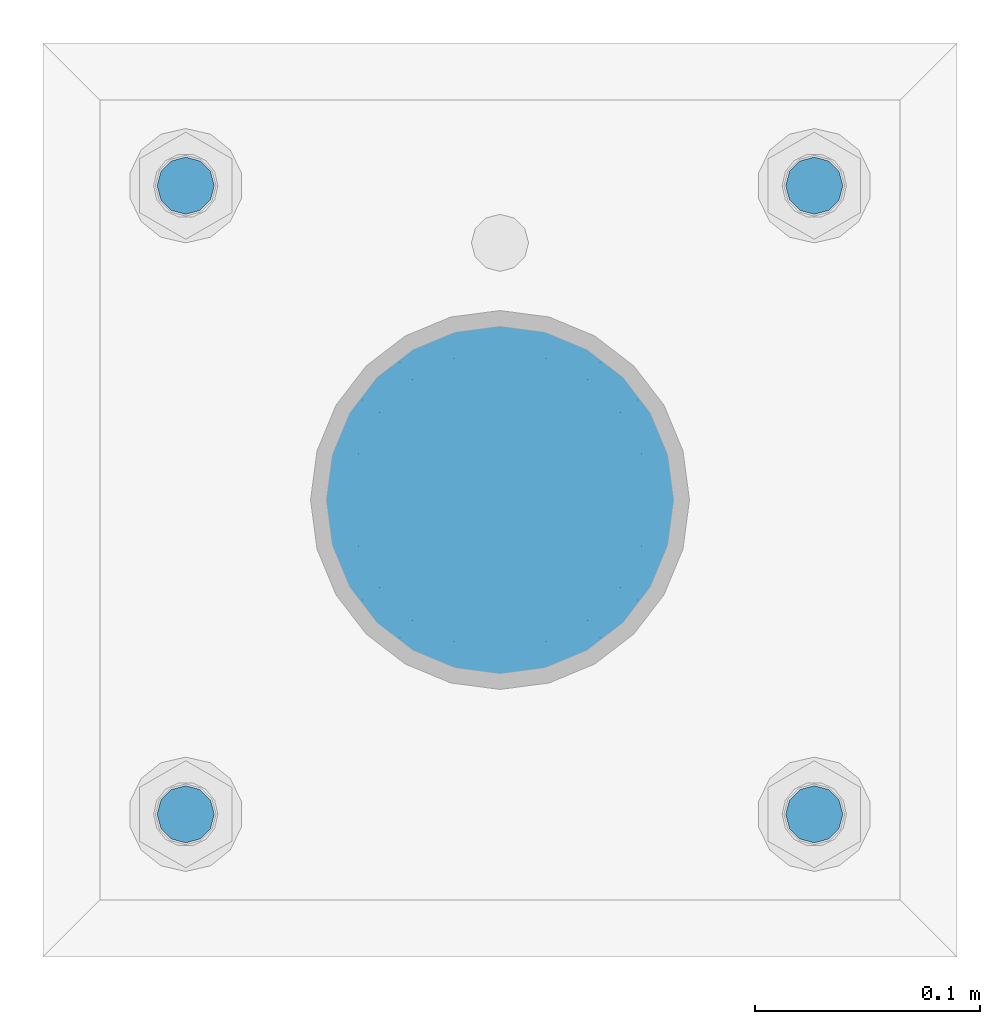
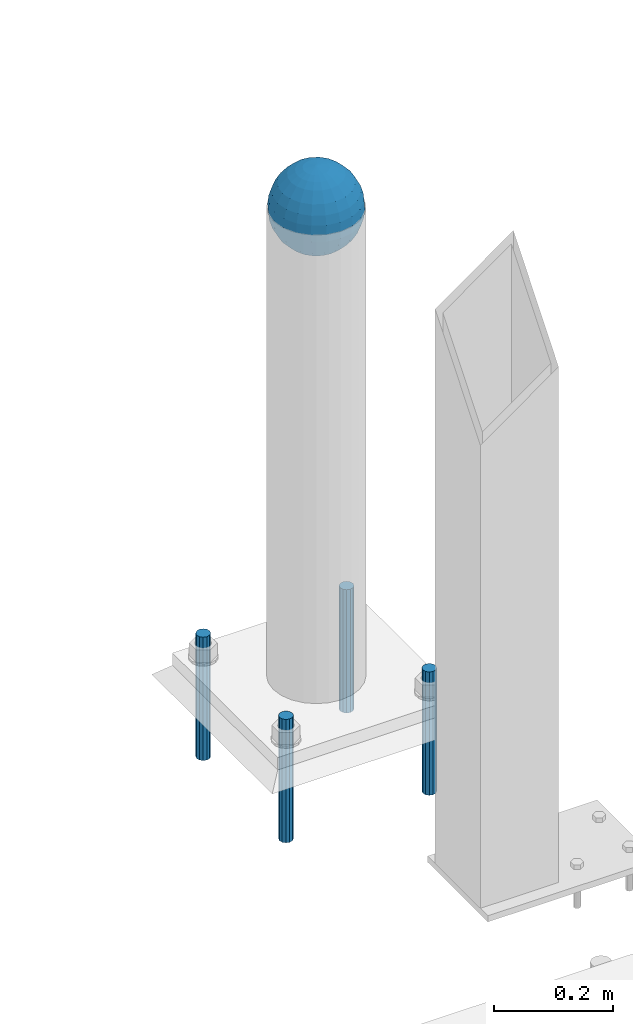
# One storey, part 1586 of 3843: 5 columns, 2 elements without a shape of their own.
"""IFC2X3 building model written with IfcOpenShell, lengths in millimetres."""

from ifc_helpers import new_model, si_unit, frame, origin_with_axes, place, context, subcontext, project, spatial, faceted_brep, material, type_object, element, aggregate, save


model = new_model("IFC2X3")

# Units and contexts
model_context = context("Model", 3, precision=1e-05, world=origin_with_axes())
body_context = subcontext(model_context, "Body", "Model", "MODEL_VIEW")
ifc_project = project(units=[si_unit("LENGTHUNIT", "METRE", prefix="MILLI"), si_unit("AREAUNIT", "SQUARE_METRE"), si_unit("VOLUMEUNIT", "CUBIC_METRE"), si_unit("MASSUNIT", "GRAM", prefix="KILO"), si_unit("TIMEUNIT", "SECOND"), si_unit("PLANEANGLEUNIT", "RADIAN"), si_unit("SOLIDANGLEUNIT", "STERADIAN"), si_unit("THERMODYNAMICTEMPERATUREUNIT", "DEGREE_CELSIUS"), si_unit("LUMINOUSINTENSITYUNIT", "LUMEN")], contexts=[model_context])

# Site, building, storey
site_placement = place(None, origin_with_axes())
site = spatial("IfcSite", under=ifc_project, at=site_placement, CompositionType="ELEMENT")
building_placement = place(site_placement, origin_with_axes())
building = spatial("IfcBuilding", under=site, at=building_placement, Name="Undefined", CompositionType="ELEMENT")
storey_placement = place(building_placement, origin_with_axes())
storey = spatial("IfcBuildingStorey", under=building, at=storey_placement, Name="Undefined", CompositionType="ELEMENT", Elevation=0.0)

# Assembly, column
assembly_1_placement = place(storey_placement, origin_with_axes())
assembly_1 = element("IfcElementAssembly", 1, at=assembly_1_placement, inside=storey, Name="CONC. FILL", AssemblyPlace="NOTDEFINED", PredefinedType="REINFORCEMENT_UNIT")
ifc_material_1 = material(Name="CONCRETE/1500")
column_type_1 = type_object("IfcColumnType", PredefinedType="NOTDEFINED")
column_1_placement = place(assembly_1_placement, frame((48488.6, 93129.1, 31411.8625), z_axis=(-1.0, 0.0, 0.0), x_axis=(0.0, 0.0, 1.0)))
column_1 = element("IfcColumn", 2, at=column_1_placement, type_object=column_type_1, material=ifc_material_1, Name="CONC. FILL", context=body_context, shape_type="Brep", body=[
    faceted_brep([(0.0, 0.0, 2.0), (0.0, -0.619999999995343, 1.89999999999964), (3.36549999999988, -7.1422259999963, 21.9814139999999), (3.36549999999988, 0.0, 23.1139999999996), (0.0, -1.17999999999302, 1.6200000000008), (3.36549999999988, -13.5910319999966, 18.6992260000006), (0.0, -1.61999999999534, 1.18000000000029), (3.36549999999988, -18.699225999997, 13.5910320000003), (0.0, -1.89999999999418, 0.6200000000008), (3.36549999999988, -21.9814139999944, 7.14222599999994), (0.0, -2.0, 0.0), (3.36549999999988, -23.1140000000014, 0.0), (0.0, -1.89999999999418, -0.6200000000008), (3.36549999999988, -21.9814139999944, -7.14222599999994), (0.0, -1.61999999999534, -1.18000000000029), (3.36549999999988, -18.699225999997, -13.5910320000003), (0.0, -1.17999999999302, -1.6200000000008), (3.36549999999988, -13.5910319999966, -18.6992260000006), (0.0, -0.619999999995343, -1.89999999999964), (3.36549999999988, -7.1422259999963, -21.9814139999999), (0.0, 0.0, -2.0), (3.36549999999988, 0.0, -23.1139999999996), (0.0, 0.619999999995343, -1.89999999999964), (3.36549999999988, 7.1422259999963, -21.9814139999999), (0.0, 1.17999999999302, -1.6200000000008), (3.36549999999988, 13.5910319999966, -18.6992260000006), (0.0, 1.61999999999534, -1.18000000000029), (3.36549999999988, 18.699225999997, -13.5910320000003), (0.0, 1.89999999999418, -0.6200000000008), (3.36549999999988, 21.9814139999944, -7.14222599999994), (0.0, 2.0, 0.0), (3.36549999999988, 23.1140000000014, 0.0), (0.0, 1.89999999999418, 0.6200000000008), (3.36549999999988, 21.9814139999944, 7.14222599999994), (0.0, 1.61999999999534, 1.18000000000029), (3.36549999999988, 18.699225999997, 13.5910320000003), (0.0, 1.17999999999302, 1.6200000000008), (3.36549999999988, 13.5910319999966, 18.6992260000006), (0.0, 0.619999999995343, 1.89999999999964), (3.36549999999988, 7.1422259999963, 21.9814139999999), (8.41374999999971, -11.1214661999984, 34.2282018000005), (8.41374999999971, 0.0, 35.9917999999998), (8.41374999999971, -21.1631784000056, 29.1173662000001), (8.41374999999971, -29.1173661999928, 21.1631784000001), (8.41374999999971, -34.2282017999969, 11.1214662000002), (8.41374999999971, -35.9918000000034, 0.0), (8.41374999999971, -34.2282017999969, -11.1214662000002), (8.41374999999971, -29.1173661999928, -21.1631784000001), (8.41374999999971, -21.1631784000056, -29.1173662000001), (8.41374999999971, -11.1214661999984, -34.2282018000005), (8.41374999999971, 0.0, -35.9917999999998), (8.41374999999971, 11.1214661999984, -34.2282018000005), (8.41374999999971, 21.1631784000056, -29.1173662000001), (8.41374999999971, 29.1173661999928, -21.1631784000001), (8.41374999999971, 34.2282017999969, -11.1214662000002), (8.41374999999971, 35.9918000000034, 0.0), (8.41374999999971, 34.2282017999969, 11.1214662000002), (8.41374999999971, 29.1173661999928, 21.1631784000001), (8.41374999999971, 21.1631784000056, 29.1173662000001), (8.41374999999971, 11.1214661999984, 34.2282018000005), (16.8274999999994, -15.3047700000025, 47.1030300000002), (16.8274999999994, 0.0, 49.5300000000007), (16.8274999999994, -29.1236400000053, 40.0697700000001), (16.8274999999994, -40.0697700000019, 29.1236399999998), (16.8274999999994, -47.1030299999984, 15.3047700000006), (16.8274999999994, -49.5299999999988, 0.0), (16.8274999999994, -47.1030299999984, -15.3047700000006), (16.8274999999994, -40.0697700000019, -29.1236399999998), (16.8274999999994, -29.1236400000053, -40.0697700000001), (16.8274999999994, -15.3047700000025, -47.1030300000002), (16.8274999999994, 0.0, -49.5300000000007), (16.8274999999994, 15.3047700000025, -47.1030300000002), (16.8274999999994, 29.1236400000053, -40.0697700000001), (16.8274999999994, 40.0697700000019, -29.1236399999998), (16.8274999999994, 47.1030299999984, -15.3047700000006), (16.8274999999994, 49.5299999999988, 0.0), (16.8274999999994, 47.1030299999984, 15.3047700000006), (16.8274999999994, 40.0697700000019, 29.1236399999998), (16.8274999999994, 29.1236400000053, 40.0697700000001), (16.8274999999994, 15.3047700000025, 47.1030300000002), (33.6549999999988, -20.4063599999936, 62.8040400000009), (33.6549999999988, 0.0, 66.0400000000009), (33.6549999999988, -38.831520000007, 53.4263599999995), (33.6549999999988, -53.4263599999977, 38.8315199999997), (33.6549999999988, -62.8040400000027, 20.4063600000009), (33.6549999999988, -66.0399999999936, 0.0), (33.6549999999988, -62.8040400000027, -20.4063600000009), (33.6549999999988, -53.4263599999977, -38.8315199999997), (33.6549999999988, -38.831520000007, -53.4263599999995), (33.6549999999988, -20.4063599999936, -62.8040400000009), (33.6549999999988, 0.0, -66.0400000000009), (33.6549999999988, 20.4063599999936, -62.8040400000009), (33.6549999999988, 38.831520000007, -53.4263599999995), (33.6549999999988, 53.4263599999977, -38.8315199999997), (33.6549999999988, 62.8040400000027, -20.4063600000009), (33.6549999999988, 66.0399999999936, 0.0), (33.6549999999988, 62.8040400000027, 20.4063600000009), (33.6549999999988, 53.4263599999977, 38.8315199999997), (33.6549999999988, 38.831520000007, 53.4263599999995), (33.6549999999988, 20.4063599999936, 62.8040400000009), (50.4824999999983, -23.3907901500061, 71.9891308499991), (50.4824999999983, 0.0, 75.6983500000006), (50.4824999999983, -44.5106298000028, 61.23996515), (50.4824999999983, -61.2399651500018, 44.5106297999992), (50.4824999999983, -71.9891308499937, 23.3907901500006), (50.4824999999983, -75.698350000006, 0.0), (50.4824999999983, -71.9891308499937, -23.3907901500006), (50.4824999999983, -61.2399651500018, -44.5106297999992), (50.4824999999983, -44.5106298000028, -61.23996515), (50.4824999999983, -23.3907901500061, -71.9891308499991), (50.4824999999983, 0.0, -75.6983500000006), (50.4824999999983, 23.3907901500061, -71.9891308499991), (50.4824999999983, 44.5106298000028, -61.23996515), (50.4824999999983, 61.2399651500018, -44.5106297999992), (50.4824999999983, 71.9891308499937, -23.3907901500006), (50.4824999999983, 75.698350000006, 0.0), (50.4824999999983, 71.9891308499937, 23.3907901500006), (50.4824999999983, 61.2399651500018, 44.5106297999992), (50.4824999999983, 44.5106298000028, 61.23996515), (50.4824999999983, 23.3907901500061, 71.9891308499991), (67.3099999999977, -24.9977910000016, 76.9349490000004), (67.3099999999977, 0.0, 80.8989999999994), (67.3099999999977, -47.5686120000028, 65.4472910000004), (67.3099999999977, -65.447291000004, 47.5686119999991), (67.3099999999977, -76.9349490000022, 24.9977909999998), (67.3099999999977, -80.8990000000049, 0.0), (67.3099999999977, -76.9349490000022, -24.9977909999998), (67.3099999999977, -65.447291000004, -47.5686119999991), (67.3099999999977, -47.5686120000028, -65.4472910000004), (67.3099999999977, -24.9977910000016, -76.9349490000004), (67.3099999999977, 0.0, -80.8989999999994), (67.3099999999977, 24.9977910000016, -76.9349490000004), (67.3099999999977, 47.5686120000028, -65.4472910000004), (67.3099999999977, 65.447291000004, -47.5686119999991), (67.3099999999977, 76.9349490000022, -24.9977909999998), (67.3099999999977, 80.8990000000049, 0.0), (67.3099999999977, 76.9349490000022, 24.9977909999998), (67.3099999999977, 65.447291000004, 47.5686119999991), (67.3099999999977, 47.5686120000028, 65.4472910000004), (67.3099999999977, 24.9977910000016, 76.9349490000004), (84.1374999999935, -25.5079499999993, 78.5050499999998), (84.1374999999935, 0.0, 82.5499999999993), (84.1374999999935, -48.5393999999942, 66.7829500000007), (84.1374999999935, -66.7829499999934, 48.5393999999997), (84.1374999999935, -78.505050000007, 25.5079499999993), (84.1374999999935, -82.5500000000029, 0.0), (84.1374999999935, -78.505050000007, -25.5079499999993), (84.1374999999935, -66.7829499999934, -48.5393999999997), (84.1374999999935, -48.5393999999942, -66.7829500000007), (84.1374999999935, -25.5079499999993, -78.5050499999998), (84.1374999999935, 0.0, -82.5499999999993), (84.1374999999935, 25.5079499999993, -78.5050499999998), (84.1374999999935, 48.5393999999942, -66.7829500000007), (84.1374999999935, 66.7829499999934, -48.5393999999997), (84.1374999999935, 78.505050000007, -25.5079499999993), (84.1374999999935, 82.5500000000029, 0.0), (84.1374999999935, 78.505050000007, 25.5079499999993), (84.1374999999935, 66.7829499999934, 48.5393999999997), (84.1374999999935, 48.5393999999942, 66.7829500000007), (84.1374999999935, 25.5079499999993, 78.5050499999998), (100.964999999993, -24.9977910000016, 76.9349490000004), (100.964999999993, 0.0, 80.8989999999994), (100.964999999993, -47.5686120000028, 65.4472910000004), (100.964999999993, -65.447291000004, 47.5686119999991), (100.964999999993, -76.9349490000022, 24.9977909999998), (100.964999999993, -80.8990000000049, 0.0), (100.964999999993, -76.9349490000022, -24.9977909999998), (100.964999999993, -65.447291000004, -47.5686119999991), (100.964999999993, -47.5686120000028, -65.4472910000004), (100.964999999993, -24.9977910000016, -76.9349490000004), (100.964999999993, 0.0, -80.8989999999994), (100.964999999993, 24.9977910000016, -76.9349490000004), (100.964999999993, 47.5686120000028, -65.4472910000004), (100.964999999993, 65.447291000004, -47.5686119999991), (100.964999999993, 76.9349490000022, -24.9977909999998), (100.964999999993, 80.8990000000049, 0.0), (100.964999999993, 76.9349490000022, 24.9977909999998), (100.964999999993, 65.447291000004, 47.5686119999991), (100.964999999993, 47.5686120000028, 65.4472910000004), (100.964999999993, 24.9977910000016, 76.9349490000004), (117.792499999992, -23.3907901500061, 71.9891308499991), (117.792499999992, 0.0, 75.6983500000006), (117.792499999992, -44.5106298000028, 61.23996515), (117.792499999992, -61.2399651500018, 44.5106297999992), (117.792499999992, -71.9891308499937, 23.3907901500006), (117.792499999992, -75.698350000006, 0.0), (117.792499999992, -71.9891308499937, -23.3907901500006), (117.792499999992, -61.2399651500018, -44.5106297999992), (117.792499999992, -44.5106298000028, -61.23996515), (117.792499999992, -23.3907901500061, -71.9891308499991), (117.792499999992, 0.0, -75.6983500000006), (117.792499999992, 23.3907901500061, -71.9891308499991), (117.792499999992, 44.5106298000028, -61.23996515), (117.792499999992, 61.2399651500018, -44.5106297999992), (117.792499999992, 71.9891308499937, -23.3907901500006), (117.792499999992, 75.698350000006, 0.0), (117.792499999992, 71.9891308499937, 23.3907901500006), (117.792499999992, 61.2399651500018, 44.5106297999992), (117.792499999992, 44.5106298000028, 61.23996515), (117.792499999992, 23.3907901500061, 71.9891308499991), (134.619999999992, -20.4063599999936, 62.8040400000009), (134.619999999992, 0.0, 66.0400000000009), (134.619999999992, -38.831520000007, 53.4263599999995), (134.619999999992, -53.4263599999977, 38.8315199999997), (134.619999999992, -62.8040400000027, 20.4063600000009), (134.619999999992, -66.0399999999936, 0.0), (134.619999999992, -62.8040400000027, -20.4063600000009), (134.619999999992, -53.4263599999977, -38.8315199999997), (134.619999999992, -38.831520000007, -53.4263599999995), (134.619999999992, -20.4063599999936, -62.8040400000009), (134.619999999992, 0.0, -66.0400000000009), (134.619999999992, 20.4063599999936, -62.8040400000009), (134.619999999992, 38.831520000007, -53.4263599999995), (134.619999999992, 53.4263599999977, -38.8315199999997), (134.619999999992, 62.8040400000027, -20.4063600000009), (134.619999999992, 66.0399999999936, 0.0), (134.619999999992, 62.8040400000027, 20.4063600000009), (134.619999999992, 53.4263599999977, 38.8315199999997), (134.619999999992, 38.831520000007, 53.4263599999995), (134.619999999992, 20.4063599999936, 62.8040400000009), (151.447499999991, -15.3047700000025, 47.1030300000002), (151.447499999991, 0.0, 49.5300000000007), (151.447499999991, -29.1236400000053, 40.0697700000001), (151.447499999991, -40.0697700000019, 29.1236399999998), (151.447499999991, -47.1030299999984, 15.3047700000006), (151.447499999991, -49.5299999999988, 0.0), (151.447499999991, -47.1030299999984, -15.3047700000006), (151.447499999991, -40.0697700000019, -29.1236399999998), (151.447499999991, -29.1236400000053, -40.0697700000001), (151.447499999991, -15.3047700000025, -47.1030300000002), (151.447499999991, 0.0, -49.5300000000007), (151.447499999991, 15.3047700000025, -47.1030300000002), (151.447499999991, 29.1236400000053, -40.0697700000001), (151.447499999991, 40.0697700000019, -29.1236399999998), (151.447499999991, 47.1030299999984, -15.3047700000006), (151.447499999991, 49.5299999999988, 0.0), (151.447499999991, 47.1030299999984, 15.3047700000006), (151.447499999991, 40.0697700000019, 29.1236399999998), (151.447499999991, 29.1236400000053, 40.0697700000001), (151.447499999991, 15.3047700000025, 47.1030300000002), (159.861249999991, -11.1214661999984, 34.2282018000005), (159.861249999991, 0.0, 35.9917999999998), (159.861249999991, -21.1631784000056, 29.1173662000001), (159.861249999991, -29.1173661999928, 21.1631784000001), (159.861249999991, -34.2282017999969, 11.1214662000002), (159.861249999991, -35.9918000000034, 0.0), (159.861249999991, -34.2282017999969, -11.1214662000002), (159.861249999991, -29.1173661999928, -21.1631784000001), (159.861249999991, -21.1631784000056, -29.1173662000001), (159.861249999991, -11.1214661999984, -34.2282018000005), (159.861249999991, 0.0, -35.9917999999998), (159.861249999991, 11.1214661999984, -34.2282018000005), (159.861249999991, 21.1631784000056, -29.1173662000001), (159.861249999991, 29.1173661999928, -21.1631784000001), (159.861249999991, 34.2282017999969, -11.1214662000002), (159.861249999991, 35.9918000000034, 0.0), (159.861249999991, 34.2282017999969, 11.1214662000002), (159.861249999991, 29.1173661999928, 21.1631784000001), (159.861249999991, 21.1631784000056, 29.1173662000001), (159.861249999991, 11.1214661999984, 34.2282018000005), (164.909499999991, -7.1422259999963, 21.9814139999999), (164.909499999991, 0.0, 23.1139999999996), (164.909499999991, -13.5910319999966, 18.6992260000006), (164.909499999991, -18.699225999997, 13.5910320000003), (164.909499999991, -21.9814139999944, 7.14222599999994), (164.909499999991, -23.1140000000014, 0.0), (164.909499999991, -21.9814139999944, -7.14222599999994), (164.909499999991, -18.699225999997, -13.5910320000003), (164.909499999991, -13.5910319999966, -18.6992260000006), (164.909499999991, -7.1422259999963, -21.9814139999999), (164.909499999991, 0.0, -23.1139999999996), (164.909499999991, 7.1422259999963, -21.9814139999999), (164.909499999991, 13.5910319999966, -18.6992260000006), (164.909499999991, 18.699225999997, -13.5910320000003), (164.909499999991, 21.9814139999944, -7.14222599999994), (164.909499999991, 23.1140000000014, 0.0), (164.909499999991, 21.9814139999944, 7.14222599999994), (164.909499999991, 18.699225999997, 13.5910320000003), (164.909499999991, 13.5910319999966, 18.6992260000006), (164.909499999991, 7.1422259999963, 21.9814139999999), (168.274999999991, -0.619999999995343, 1.89999999999964), (168.274999999991, 0.0, 2.0), (168.274999999991, -1.17999999999302, 1.6200000000008), (168.274999999991, -1.61999999999534, 1.18000000000029), (168.274999999991, -1.89999999999418, 0.6200000000008), (168.274999999991, -2.0, 0.0), (168.274999999991, -1.89999999999418, -0.6200000000008), (168.274999999991, -1.61999999999534, -1.18000000000029), (168.274999999991, -1.17999999999302, -1.6200000000008), (168.274999999991, -0.619999999995343, -1.89999999999964), (168.274999999991, 0.0, -2.0), (168.274999999991, 0.619999999995343, -1.89999999999964), (168.274999999991, 1.17999999999302, -1.6200000000008), (168.274999999991, 1.61999999999534, -1.18000000000029), (168.274999999991, 1.89999999999418, -0.6200000000008), (168.274999999991, 2.0, 0.0), (168.274999999991, 1.89999999999418, 0.6200000000008), (168.274999999991, 1.61999999999534, 1.18000000000029), (168.274999999991, 1.17999999999302, 1.6200000000008), (168.274999999991, 0.619999999995343, 1.89999999999964)], [[[0, 1, 2, 3]], [[1, 4, 5, 2]], [[4, 6, 7, 5]], [[6, 8, 9, 7]], [[8, 10, 11, 9]], [[10, 12, 13, 11]], [[12, 14, 15, 13]], [[14, 16, 17, 15]], [[16, 18, 19, 17]], [[18, 20, 21, 19]], [[20, 22, 23, 21]], [[22, 24, 25, 23]], [[24, 26, 27, 25]], [[26, 28, 29, 27]], [[28, 30, 31, 29]], [[30, 32, 33, 31]], [[32, 34, 35, 33]], [[34, 36, 37, 35]], [[36, 38, 39, 37]], [[38, 0, 3, 39]], [[38, 36, 34, 32, 30, 28, 26, 24, 22, 20, 18, 16, 14, 12, 10, 8, 6, 4, 1, 0]], [[3, 2, 40, 41]], [[2, 5, 42, 40]], [[5, 7, 43, 42]], [[7, 9, 44, 43]], [[9, 11, 45, 44]], [[11, 13, 46, 45]], [[13, 15, 47, 46]], [[15, 17, 48, 47]], [[17, 19, 49, 48]], [[19, 21, 50, 49]], [[21, 23, 51, 50]], [[23, 25, 52, 51]], [[25, 27, 53, 52]], [[27, 29, 54, 53]], [[29, 31, 55, 54]], [[31, 33, 56, 55]], [[33, 35, 57, 56]], [[35, 37, 58, 57]], [[37, 39, 59, 58]], [[39, 3, 41, 59]], [[41, 40, 60, 61]], [[40, 42, 62, 60]], [[42, 43, 63, 62]], [[43, 44, 64, 63]], [[44, 45, 65, 64]], [[45, 46, 66, 65]], [[46, 47, 67, 66]], [[47, 48, 68, 67]], [[48, 49, 69, 68]], [[49, 50, 70, 69]], [[50, 51, 71, 70]], [[51, 52, 72, 71]], [[52, 53, 73, 72]], [[53, 54, 74, 73]], [[54, 55, 75, 74]], [[55, 56, 76, 75]], [[56, 57, 77, 76]], [[57, 58, 78, 77]], [[58, 59, 79, 78]], [[59, 41, 61, 79]], [[61, 60, 80, 81]], [[60, 62, 82, 80]], [[62, 63, 83, 82]], [[63, 64, 84, 83]], [[64, 65, 85, 84]], [[65, 66, 86, 85]], [[66, 67, 87, 86]], [[67, 68, 88, 87]], [[68, 69, 89, 88]], [[69, 70, 90, 89]], [[70, 71, 91, 90]], [[71, 72, 92, 91]], [[72, 73, 93, 92]], [[73, 74, 94, 93]], [[74, 75, 95, 94]], [[75, 76, 96, 95]], [[76, 77, 97, 96]], [[77, 78, 98, 97]], [[78, 79, 99, 98]], [[79, 61, 81, 99]], [[81, 80, 100, 101]], [[80, 82, 102, 100]], [[82, 83, 103, 102]], [[83, 84, 104, 103]], [[84, 85, 105, 104]], [[85, 86, 106, 105]], [[86, 87, 107, 106]], [[87, 88, 108, 107]], [[88, 89, 109, 108]], [[89, 90, 110, 109]], [[90, 91, 111, 110]], [[91, 92, 112, 111]], [[92, 93, 113, 112]], [[93, 94, 114, 113]], [[94, 95, 115, 114]], [[95, 96, 116, 115]], [[96, 97, 117, 116]], [[97, 98, 118, 117]], [[98, 99, 119, 118]], [[99, 81, 101, 119]], [[101, 100, 120, 121]], [[100, 102, 122, 120]], [[102, 103, 123, 122]], [[103, 104, 124, 123]], [[104, 105, 125, 124]], [[105, 106, 126, 125]], [[106, 107, 127, 126]], [[107, 108, 128, 127]], [[108, 109, 129, 128]], [[109, 110, 130, 129]], [[110, 111, 131, 130]], [[111, 112, 132, 131]], [[112, 113, 133, 132]], [[113, 114, 134, 133]], [[114, 115, 135, 134]], [[115, 116, 136, 135]], [[116, 117, 137, 136]], [[117, 118, 138, 137]], [[118, 119, 139, 138]], [[119, 101, 121, 139]], [[121, 120, 140, 141]], [[120, 122, 142, 140]], [[122, 123, 143, 142]], [[123, 124, 144, 143]], [[124, 125, 145, 144]], [[125, 126, 146, 145]], [[126, 127, 147, 146]], [[127, 128, 148, 147]], [[128, 129, 149, 148]], [[129, 130, 150, 149]], [[130, 131, 151, 150]], [[131, 132, 152, 151]], [[132, 133, 153, 152]], [[133, 134, 154, 153]], [[134, 135, 155, 154]], [[135, 136, 156, 155]], [[136, 137, 157, 156]], [[137, 138, 158, 157]], [[138, 139, 159, 158]], [[139, 121, 141, 159]], [[141, 140, 160, 161]], [[140, 142, 162, 160]], [[142, 143, 163, 162]], [[143, 144, 164, 163]], [[144, 145, 165, 164]], [[145, 146, 166, 165]], [[146, 147, 167, 166]], [[147, 148, 168, 167]], [[148, 149, 169, 168]], [[149, 150, 170, 169]], [[150, 151, 171, 170]], [[151, 152, 172, 171]], [[152, 153, 173, 172]], [[153, 154, 174, 173]], [[154, 155, 175, 174]], [[155, 156, 176, 175]], [[156, 157, 177, 176]], [[157, 158, 178, 177]], [[158, 159, 179, 178]], [[159, 141, 161, 179]], [[161, 160, 180, 181]], [[160, 162, 182, 180]], [[162, 163, 183, 182]], [[163, 164, 184, 183]], [[164, 165, 185, 184]], [[165, 166, 186, 185]], [[166, 167, 187, 186]], [[167, 168, 188, 187]], [[168, 169, 189, 188]], [[169, 170, 190, 189]], [[170, 171, 191, 190]], [[171, 172, 192, 191]], [[172, 173, 193, 192]], [[173, 174, 194, 193]], [[174, 175, 195, 194]], [[175, 176, 196, 195]], [[176, 177, 197, 196]], [[177, 178, 198, 197]], [[178, 179, 199, 198]], [[179, 161, 181, 199]], [[181, 180, 200, 201]], [[180, 182, 202, 200]], [[182, 183, 203, 202]], [[183, 184, 204, 203]], [[184, 185, 205, 204]], [[185, 186, 206, 205]], [[186, 187, 207, 206]], [[187, 188, 208, 207]], [[188, 189, 209, 208]], [[189, 190, 210, 209]], [[190, 191, 211, 210]], [[191, 192, 212, 211]], [[192, 193, 213, 212]], [[193, 194, 214, 213]], [[194, 195, 215, 214]], [[195, 196, 216, 215]], [[196, 197, 217, 216]], [[197, 198, 218, 217]], [[198, 199, 219, 218]], [[199, 181, 201, 219]], [[201, 200, 220, 221]], [[200, 202, 222, 220]], [[202, 203, 223, 222]], [[203, 204, 224, 223]], [[204, 205, 225, 224]], [[205, 206, 226, 225]], [[206, 207, 227, 226]], [[207, 208, 228, 227]], [[208, 209, 229, 228]], [[209, 210, 230, 229]], [[210, 211, 231, 230]], [[211, 212, 232, 231]], [[212, 213, 233, 232]], [[213, 214, 234, 233]], [[214, 215, 235, 234]], [[215, 216, 236, 235]], [[216, 217, 237, 236]], [[217, 218, 238, 237]], [[218, 219, 239, 238]], [[219, 201, 221, 239]], [[221, 220, 240, 241]], [[220, 222, 242, 240]], [[222, 223, 243, 242]], [[223, 224, 244, 243]], [[224, 225, 245, 244]], [[225, 226, 246, 245]], [[226, 227, 247, 246]], [[227, 228, 248, 247]], [[228, 229, 249, 248]], [[229, 230, 250, 249]], [[230, 231, 251, 250]], [[231, 232, 252, 251]], [[232, 233, 253, 252]], [[233, 234, 254, 253]], [[234, 235, 255, 254]], [[235, 236, 256, 255]], [[236, 237, 257, 256]], [[237, 238, 258, 257]], [[238, 239, 259, 258]], [[239, 221, 241, 259]], [[241, 240, 260, 261]], [[240, 242, 262, 260]], [[242, 243, 263, 262]], [[243, 244, 264, 263]], [[244, 245, 265, 264]], [[245, 246, 266, 265]], [[246, 247, 267, 266]], [[247, 248, 268, 267]], [[248, 249, 269, 268]], [[249, 250, 270, 269]], [[250, 251, 271, 270]], [[251, 252, 272, 271]], [[252, 253, 273, 272]], [[253, 254, 274, 273]], [[254, 255, 275, 274]], [[255, 256, 276, 275]], [[256, 257, 277, 276]], [[257, 258, 278, 277]], [[258, 259, 279, 278]], [[259, 241, 261, 279]], [[261, 260, 280, 281]], [[260, 262, 282, 280]], [[262, 263, 283, 282]], [[263, 264, 284, 283]], [[264, 265, 285, 284]], [[265, 266, 286, 285]], [[266, 267, 287, 286]], [[267, 268, 288, 287]], [[268, 269, 289, 288]], [[269, 270, 290, 289]], [[270, 271, 291, 290]], [[271, 272, 292, 291]], [[272, 273, 293, 292]], [[273, 274, 294, 293]], [[274, 275, 295, 294]], [[275, 276, 296, 295]], [[276, 277, 297, 296]], [[277, 278, 298, 297]], [[278, 279, 299, 298]], [[279, 261, 281, 299]], [[282, 283, 284, 285, 286, 287, 288, 289, 290, 291, 292, 293, 294, 295, 296, 297, 298, 299, 281, 280]]]),
])
aggregate(assembly_1, [column_1])

# Assembly, columns
assembly_2_placement = place(storey_placement, origin_with_axes())
assembly_2 = element("IfcElementAssembly", 3, at=assembly_2_placement, inside=storey, Name="TEMPLATE", AssemblyPlace="NOTDEFINED", PredefinedType="RIGID_FRAME")
ifc_material_2 = material(Name="STEEL/316 SS")
column_type_2 = type_object("IfcColumnType", PredefinedType="NOTDEFINED")
column_2_placement = place(assembly_2_placement, frame((48628.3, 92989.4, 30581.6), z_axis=(1.0, 0.0, 0.0), x_axis=(0.0, 0.0, -1.0)))
column_2 = element("IfcColumn", 4, at=column_2_placement, type_object=column_type_2, material=ifc_material_2, Name="ANCHOR_ROD", context=body_context, shape_type="Brep", body=[
    faceted_brep([(0.0, -12.6999999999971, 0.0), (0.0, -10.9985226280696, -6.34999999999854), (253.999, -10.9985226280696, -6.34999999999854), (253.999, -12.6999999999971, 0.0), (0.0, -6.35000000000582, -10.9985226280623), (253.999, -6.35000000000582, -10.9985226280623), (0.0, 0.0, -12.6999999999971), (253.999, 0.0, -12.6999999999971), (0.0, 6.35000000000582, -10.9985226280623), (253.999, 6.35000000000582, -10.9985226280623), (0.0, 10.9985226280696, -6.34999999999854), (253.999, 10.9985226280696, -6.34999999999854), (0.0, 12.6999999999971, 0.0), (253.999, 12.6999999999971, 0.0), (0.0, 10.9985226280696, 6.34999999999854), (253.999, 10.9985226280696, 6.34999999999854), (0.0, 6.35000000000582, 10.9985226280623), (253.999, 6.35000000000582, 10.9985226280623), (0.0, 0.0, 12.6999999999971), (253.999, 0.0, 12.6999999999971), (0.0, -6.35000000000582, 10.9985226280623), (253.999, -6.35000000000582, 10.9985226280623), (0.0, -10.9985226280696, 6.34999999999854), (253.999, -10.9985226280696, 6.34999999999854)], [[[0, 1, 2, 3]], [[1, 4, 5, 2]], [[4, 6, 7, 5]], [[6, 8, 9, 7]], [[8, 10, 11, 9]], [[10, 12, 13, 11]], [[12, 14, 15, 13]], [[14, 16, 17, 15]], [[16, 18, 19, 17]], [[18, 20, 21, 19]], [[20, 22, 23, 21]], [[22, 0, 3, 23]], [[5, 7, 9, 11, 13, 15, 17, 19, 21, 23, 3, 2]], [[22, 20, 18, 16, 14, 12, 10, 8, 6, 4, 1, 0]]]),
])
column_3_placement = place(assembly_2_placement, frame((48628.3, 93268.8, 30581.6), z_axis=(-1.0, 0.0, 0.0), x_axis=(0.0, 0.0, -1.0)))
column_3 = element("IfcColumn", 5, at=column_3_placement, type_object=column_type_2, material=ifc_material_2, Name="ANCHOR_ROD", context=body_context, shape_type="Brep", body=[
    faceted_brep([(0.0, -12.6999999999971, 0.0), (0.0, -10.9985226280696, -6.34999999999854), (253.999, -10.9985226280696, -6.34999999999854), (253.999, -12.6999999999971, 0.0), (0.0, -6.35000000000582, -10.9985226280623), (253.999, -6.35000000000582, -10.9985226280623), (0.0, 0.0, -12.6999999999971), (253.999, 0.0, -12.6999999999971), (0.0, 6.35000000000582, -10.9985226280623), (253.999, 6.35000000000582, -10.9985226280623), (0.0, 10.9985226280696, -6.34999999999854), (253.999, 10.9985226280696, -6.34999999999854), (0.0, 12.6999999999971, 0.0), (253.999, 12.6999999999971, 0.0), (0.0, 10.9985226280696, 6.34999999999854), (253.999, 10.9985226280696, 6.34999999999854), (0.0, 6.35000000000582, 10.9985226280623), (253.999, 6.35000000000582, 10.9985226280623), (0.0, 0.0, 12.6999999999971), (253.999, 0.0, 12.6999999999971), (0.0, -6.35000000000582, 10.9985226280623), (253.999, -6.35000000000582, 10.9985226280623), (0.0, -10.9985226280696, 6.34999999999854), (253.999, -10.9985226280696, 6.34999999999854)], [[[0, 1, 2, 3]], [[1, 4, 5, 2]], [[4, 6, 7, 5]], [[6, 8, 9, 7]], [[8, 10, 11, 9]], [[10, 12, 13, 11]], [[12, 14, 15, 13]], [[14, 16, 17, 15]], [[16, 18, 19, 17]], [[18, 20, 21, 19]], [[20, 22, 23, 21]], [[22, 0, 3, 23]], [[5, 7, 9, 11, 13, 15, 17, 19, 21, 23, 3, 2]], [[22, 20, 18, 16, 14, 12, 10, 8, 6, 4, 1, 0]]]),
])
column_4_placement = place(assembly_2_placement, frame((48348.9, 92989.4, 30581.6), z_axis=(1.0, 0.0, 0.0), x_axis=(0.0, 0.0, -1.0)))
column_4 = element("IfcColumn", 6, at=column_4_placement, type_object=column_type_2, material=ifc_material_2, Name="ANCHOR_ROD", context=body_context, shape_type="Brep", body=[
    faceted_brep([(0.0, -12.6999999999971, 0.0), (0.0, -10.9985226280696, -6.34999999999854), (253.999, -10.9985226280696, -6.34999999999854), (253.999, -12.6999999999971, 0.0), (0.0, -6.35000000000582, -10.9985226280623), (253.999, -6.35000000000582, -10.9985226280623), (0.0, 0.0, -12.6999999999971), (253.999, 0.0, -12.6999999999971), (0.0, 6.35000000000582, -10.9985226280623), (253.999, 6.35000000000582, -10.9985226280623), (0.0, 10.9985226280696, -6.34999999999854), (253.999, 10.9985226280696, -6.34999999999854), (0.0, 12.6999999999971, 0.0), (253.999, 12.6999999999971, 0.0), (0.0, 10.9985226280696, 6.34999999999854), (253.999, 10.9985226280696, 6.34999999999854), (0.0, 6.35000000000582, 10.9985226280623), (253.999, 6.35000000000582, 10.9985226280623), (0.0, 0.0, 12.6999999999971), (253.999, 0.0, 12.6999999999971), (0.0, -6.35000000000582, 10.9985226280623), (253.999, -6.35000000000582, 10.9985226280623), (0.0, -10.9985226280696, 6.34999999999854), (253.999, -10.9985226280696, 6.34999999999854)], [[[0, 1, 2, 3]], [[1, 4, 5, 2]], [[4, 6, 7, 5]], [[6, 8, 9, 7]], [[8, 10, 11, 9]], [[10, 12, 13, 11]], [[12, 14, 15, 13]], [[14, 16, 17, 15]], [[16, 18, 19, 17]], [[18, 20, 21, 19]], [[20, 22, 23, 21]], [[22, 0, 3, 23]], [[5, 7, 9, 11, 13, 15, 17, 19, 21, 23, 3, 2]], [[22, 20, 18, 16, 14, 12, 10, 8, 6, 4, 1, 0]]]),
])
column_5_placement = place(assembly_2_placement, frame((48348.9, 93268.8, 30581.6), z_axis=(-1.0, 0.0, 0.0), x_axis=(0.0, 0.0, -1.0)))
column_5 = element("IfcColumn", 7, at=column_5_placement, type_object=column_type_2, material=ifc_material_2, Name="ANCHOR_ROD", context=body_context, shape_type="Brep", body=[
    faceted_brep([(0.0, -12.6999999999971, 0.0), (0.0, -10.9985226280696, -6.34999999999854), (253.999, -10.9985226280696, -6.34999999999854), (253.999, -12.6999999999971, 0.0), (0.0, -6.35000000000582, -10.9985226280623), (253.999, -6.35000000000582, -10.9985226280623), (0.0, 0.0, -12.6999999999971), (253.999, 0.0, -12.6999999999971), (0.0, 6.35000000000582, -10.9985226280623), (253.999, 6.35000000000582, -10.9985226280623), (0.0, 10.9985226280696, -6.34999999999854), (253.999, 10.9985226280696, -6.34999999999854), (0.0, 12.6999999999971, 0.0), (253.999, 12.6999999999971, 0.0), (0.0, 10.9985226280696, 6.34999999999854), (253.999, 10.9985226280696, 6.34999999999854), (0.0, 6.35000000000582, 10.9985226280623), (253.999, 6.35000000000582, 10.9985226280623), (0.0, 0.0, 12.6999999999971), (253.999, 0.0, 12.6999999999971), (0.0, -6.35000000000582, 10.9985226280623), (253.999, -6.35000000000582, 10.9985226280623), (0.0, -10.9985226280696, 6.34999999999854), (253.999, -10.9985226280696, 6.34999999999854)], [[[0, 1, 2, 3]], [[1, 4, 5, 2]], [[4, 6, 7, 5]], [[6, 8, 9, 7]], [[8, 10, 11, 9]], [[10, 12, 13, 11]], [[12, 14, 15, 13]], [[14, 16, 17, 15]], [[16, 18, 19, 17]], [[18, 20, 21, 19]], [[20, 22, 23, 21]], [[22, 0, 3, 23]], [[5, 7, 9, 11, 13, 15, 17, 19, 21, 23, 3, 2]], [[22, 20, 18, 16, 14, 12, 10, 8, 6, 4, 1, 0]]]),
])
aggregate(assembly_2, [column_2, column_3, column_4, column_5])

save(model, "model.ifc")
